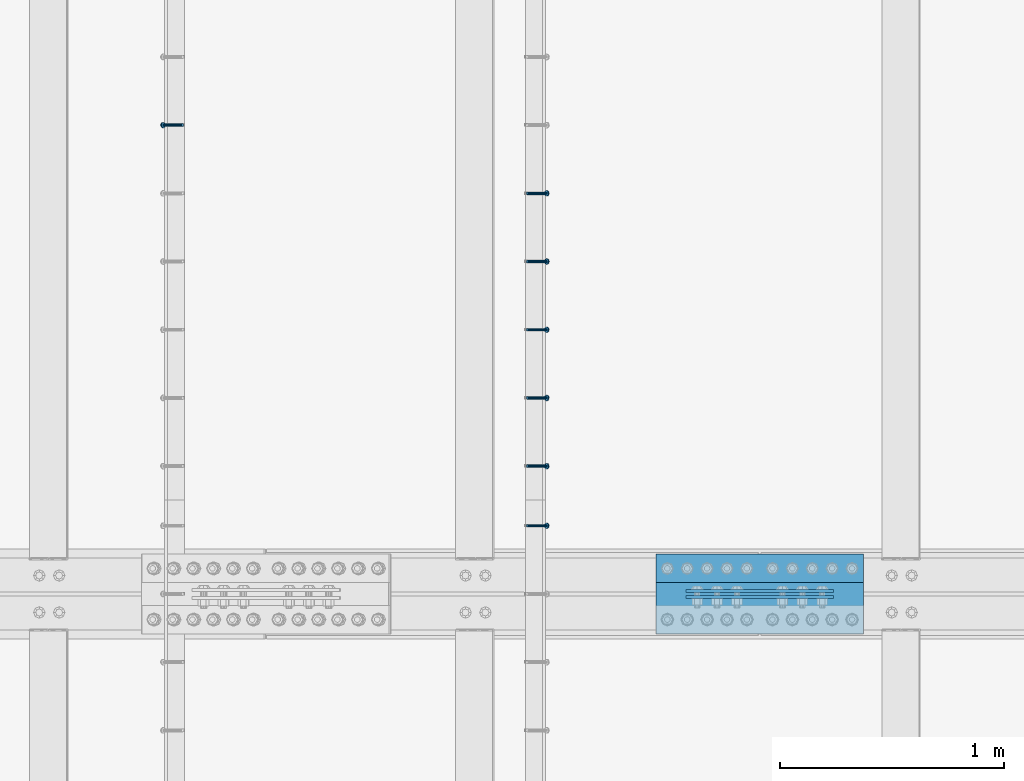
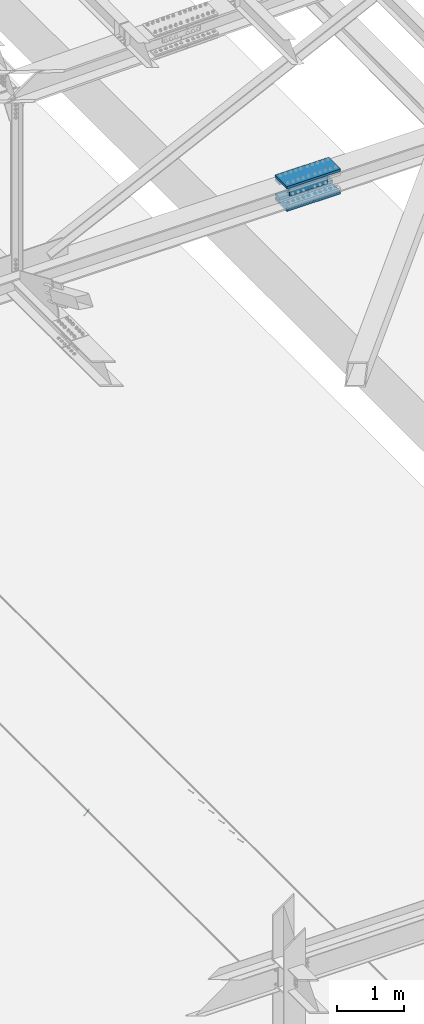
# One storey, part 2273 of 3843: 7 members, 6 beams, 4 elements without a shape of their own.
"""IFC2X3 building model written with IfcOpenShell, lengths in millimetres."""

from ifc_helpers import new_model, si_unit, frame, origin_with_axes, place, context, subcontext, project, spatial, faceted_brep, material, type_object, element, aggregate, save


model = new_model("IFC2X3")

# Units and contexts
model_context = context("Model", 3, precision=1e-05, world=origin_with_axes())
body_context = subcontext(model_context, "Body", "Model", "MODEL_VIEW")
ifc_project = project(units=[si_unit("LENGTHUNIT", "METRE", prefix="MILLI"), si_unit("AREAUNIT", "SQUARE_METRE"), si_unit("VOLUMEUNIT", "CUBIC_METRE"), si_unit("MASSUNIT", "GRAM", prefix="KILO"), si_unit("TIMEUNIT", "SECOND"), si_unit("PLANEANGLEUNIT", "RADIAN"), si_unit("SOLIDANGLEUNIT", "STERADIAN"), si_unit("THERMODYNAMICTEMPERATUREUNIT", "DEGREE_CELSIUS"), si_unit("LUMINOUSINTENSITYUNIT", "LUMEN")], contexts=[model_context])

# Site, building, storey
site_placement = place(None, origin_with_axes())
site = spatial("IfcSite", under=ifc_project, at=site_placement, CompositionType="ELEMENT")
building_placement = place(site_placement, origin_with_axes())
building = spatial("IfcBuilding", under=site, at=building_placement, Name="Undefined", CompositionType="ELEMENT")
storey_placement = place(building_placement, origin_with_axes())
storey = spatial("IfcBuildingStorey", under=building, at=storey_placement, Name="Undefined", CompositionType="ELEMENT", Elevation=0.0)

# Assembly, member
assembly_1_placement = place(storey_placement, origin_with_axes())
assembly_1 = element("IfcElementAssembly", 1, at=assembly_1_placement, inside=storey, Name="EMBED_ANGLE", AssemblyPlace="NOTDEFINED", PredefinedType="RIGID_FRAME")
ifc_material_1 = material(Name="STEEL/A108")
member_type = type_object("IfcMemberType", PredefinedType="NOTDEFINED")
member_1_placement = place(assembly_1_placement, frame((66677.3495, 34150.4271953125, 30446.6625), z_axis=(0.0, 1.0, 0.0), x_axis=(0.707106781186548, 0.0, -0.707106781186548)))
member_1 = element("IfcMember", 2, at=member_1_placement, type_object=member_type, material=ifc_material_1, Name="HEADED STUD ANCHOR", context=body_context, shape_type="Brep", body=[
    faceted_brep([(7.27595761418343e-12, -3.18000006675175, 5.5), (0.0, -5.49999999998363, 3.1800000667572), (118.110000000976, -5.49999999999091, 3.1800000667572), (118.110000000983, -3.18000006675175, 5.5), (0.0, -6.3499999046162, 0.0), (118.110000000968, -6.34999990461256, 0.0), (0.0, -5.49999999998363, -3.1800000667572), (118.110000000976, -5.49999999999091, -3.1800000667572), (7.27595761418343e-12, -3.18000006675175, -5.5), (118.110000000983, -3.18000006675175, -5.5), (7.27595761418343e-12, -1.81898940354586e-12, -6.34999990463257), (118.110000000968, -1.81898940354586e-12, -6.34999990463257), (0.0, 3.18000006675175, -5.5), (118.110000000968, 3.18000006674811, -5.5), (7.27595761418343e-12, 5.49999999998363, -3.1800000667572), (118.110000000983, 5.49999999998363, -3.1800000667572), (7.27595761418343e-12, 6.3499999046162, 0.0), (118.110000000976, 6.34999990461256, 0.0), (7.27595761418343e-12, 5.49999999998363, 3.1800000667572), (118.110000000983, 5.49999999998363, 3.1800000667572), (0.0, 3.18000006675175, 5.5), (118.110000000968, 3.18000006674811, 5.5), (7.27595761418343e-12, -1.81898940354586e-12, 6.34999990463257), (118.110000000968, -1.81898940354586e-12, 6.34999990463257), (120.650000000991, -10.9899997710909, 6.34999990463257), (120.650000000998, -6.34000015257152, 10.9899997711182), (120.650000000991, -12.6999998092379, 0.0), (120.650000000991, -10.9899997710909, -6.34999990463257), (120.650000000998, -6.34000015257152, -10.9899997711182), (120.650000000991, -1.81898940354586e-12, -12.6899995803833), (120.650000000991, 6.34000015257152, -10.9899997711182), (120.650000000998, 10.9899997710909, -6.34999990463257), (120.650000000991, 12.6999998092342, 0.0), (120.650000000998, 10.9899997710909, 6.34999990463257), (120.650000000991, 6.34000015257152, 10.9899997711182), (120.650000000991, -1.81898940354586e-12, 12.6899995803833), (127.000000001048, -10.9899997710945, 6.34999990463257), (127.000000001048, -6.34000015257152, 10.9899997711182), (127.000000001048, -12.6999998092342, 0.0), (127.000000001048, -10.9899997710945, -6.34999990463257), (127.000000001048, -6.34000015257152, -10.9899997711182), (127.000000001048, 1.81898940354586e-12, -12.6899995803833), (127.000000001048, 6.34000015256788, -10.9899997711182), (127.000000001048, 10.9899997710909, -6.34999990463257), (127.000000001048, 12.6999998092379, 0.0), (127.000000001048, 10.9899997710909, 6.34999990463257), (127.000000001048, 6.34000015256788, 10.9899997711182), (127.000000001048, 1.81898940354586e-12, 12.6899995803833)], [[[0, 1, 2, 3]], [[1, 4, 5, 2]], [[4, 6, 7, 5]], [[6, 8, 9, 7]], [[8, 10, 11, 9]], [[10, 12, 13, 11]], [[12, 14, 15, 13]], [[14, 16, 17, 15]], [[16, 18, 19, 17]], [[18, 20, 21, 19]], [[20, 22, 23, 21]], [[22, 0, 3, 23]], [[22, 20, 18, 16, 14, 12, 10, 8, 6, 4, 1, 0]], [[3, 2, 24, 25]], [[2, 5, 26, 24]], [[5, 7, 27, 26]], [[7, 9, 28, 27]], [[9, 11, 29, 28]], [[11, 13, 30, 29]], [[13, 15, 31, 30]], [[15, 17, 32, 31]], [[17, 19, 33, 32]], [[19, 21, 34, 33]], [[21, 23, 35, 34]], [[23, 3, 25, 35]], [[25, 24, 36, 37]], [[24, 26, 38, 36]], [[26, 27, 39, 38]], [[27, 28, 40, 39]], [[28, 29, 41, 40]], [[29, 30, 42, 41]], [[30, 31, 43, 42]], [[31, 32, 44, 43]], [[32, 33, 45, 44]], [[33, 34, 46, 45]], [[34, 35, 47, 46]], [[35, 25, 37, 47]], [[38, 39, 40, 41, 42, 43, 44, 45, 46, 47, 37, 36]]]),
])
aggregate(assembly_1, [member_1])

# Assembly, members
assembly_2_placement = place(storey_placement, origin_with_axes())
assembly_2 = element("IfcElementAssembly", 3, at=assembly_2_placement, inside=storey, Name="EMBED_ANGLE", AssemblyPlace="NOTDEFINED", PredefinedType="RIGID_FRAME")
member_2_placement = place(assembly_2_placement, frame((66677.3495, 34417.000201416, 30446.6625), z_axis=(0.0, 1.0, 0.0), x_axis=(0.707106781186548, 0.0, -0.707106781186548)))
member_2 = element("IfcMember", 4, at=member_2_placement, type_object=member_type, material=ifc_material_1, Name="HEADED STUD ANCHOR", context=body_context, shape_type="Brep", body=[
    faceted_brep([(7.27595761418343e-12, -3.18000006675175, 5.5), (0.0, -5.49999999998363, 3.1800000667572), (118.110000000976, -5.49999999999091, 3.1800000667572), (118.110000000983, -3.18000006675175, 5.5), (0.0, -6.3499999046162, 0.0), (118.110000000968, -6.34999990461256, 0.0), (0.0, -5.49999999998363, -3.1800000667572), (118.110000000976, -5.49999999999091, -3.1800000667572), (7.27595761418343e-12, -3.18000006675175, -5.5), (118.110000000983, -3.18000006675175, -5.5), (7.27595761418343e-12, -1.81898940354586e-12, -6.34999990463257), (118.110000000968, -1.81898940354586e-12, -6.34999990463257), (0.0, 3.18000006675175, -5.5), (118.110000000968, 3.18000006674811, -5.5), (7.27595761418343e-12, 5.49999999998363, -3.1800000667572), (118.110000000983, 5.49999999998363, -3.1800000667572), (7.27595761418343e-12, 6.3499999046162, 0.0), (118.110000000976, 6.34999990461256, 0.0), (7.27595761418343e-12, 5.49999999998363, 3.1800000667572), (118.110000000983, 5.49999999998363, 3.1800000667572), (0.0, 3.18000006675175, 5.5), (118.110000000968, 3.18000006674811, 5.5), (7.27595761418343e-12, -1.81898940354586e-12, 6.34999990463257), (118.110000000968, -1.81898940354586e-12, 6.34999990463257), (120.650000000991, -10.9899997710909, 6.34999990463257), (120.650000000998, -6.34000015257152, 10.9899997711182), (120.650000000991, -12.6999998092379, 0.0), (120.650000000991, -10.9899997710909, -6.34999990463257), (120.650000000998, -6.34000015257152, -10.9899997711182), (120.650000000991, -1.81898940354586e-12, -12.6899995803833), (120.650000000991, 6.34000015257152, -10.9899997711182), (120.650000000998, 10.9899997710909, -6.34999990463257), (120.650000000991, 12.6999998092342, 0.0), (120.650000000998, 10.9899997710909, 6.34999990463257), (120.650000000991, 6.34000015257152, 10.9899997711182), (120.650000000991, -1.81898940354586e-12, 12.6899995803833), (127.000000001048, -10.9899997710945, 6.34999990463257), (127.000000001048, -6.34000015257152, 10.9899997711182), (127.000000001048, -12.6999998092342, 0.0), (127.000000001048, -10.9899997710945, -6.34999990463257), (127.000000001048, -6.34000015257152, -10.9899997711182), (127.000000001048, 1.81898940354586e-12, -12.6899995803833), (127.000000001048, 6.34000015256788, -10.9899997711182), (127.000000001048, 10.9899997710909, -6.34999990463257), (127.000000001048, 12.6999998092379, 0.0), (127.000000001048, 10.9899997710909, 6.34999990463257), (127.000000001048, 6.34000015256788, 10.9899997711182), (127.000000001048, 1.81898940354586e-12, 12.6899995803833)], [[[0, 1, 2, 3]], [[1, 4, 5, 2]], [[4, 6, 7, 5]], [[6, 8, 9, 7]], [[8, 10, 11, 9]], [[10, 12, 13, 11]], [[12, 14, 15, 13]], [[14, 16, 17, 15]], [[16, 18, 19, 17]], [[18, 20, 21, 19]], [[20, 22, 23, 21]], [[22, 0, 3, 23]], [[22, 20, 18, 16, 14, 12, 10, 8, 6, 4, 1, 0]], [[3, 2, 24, 25]], [[2, 5, 26, 24]], [[5, 7, 27, 26]], [[7, 9, 28, 27]], [[9, 11, 29, 28]], [[11, 13, 30, 29]], [[13, 15, 31, 30]], [[15, 17, 32, 31]], [[17, 19, 33, 32]], [[19, 21, 34, 33]], [[21, 23, 35, 34]], [[23, 3, 25, 35]], [[25, 24, 36, 37]], [[24, 26, 38, 36]], [[26, 27, 39, 38]], [[27, 28, 40, 39]], [[28, 29, 41, 40]], [[29, 30, 42, 41]], [[30, 31, 43, 42]], [[31, 32, 44, 43]], [[32, 33, 45, 44]], [[33, 34, 46, 45]], [[34, 35, 47, 46]], [[35, 25, 37, 47]], [[38, 39, 40, 41, 42, 43, 44, 45, 46, 47, 37, 36]]]),
])
member_3_placement = place(assembly_2_placement, frame((66677.3495, 34721.800201416, 30446.6625), z_axis=(0.0, 1.0, 0.0), x_axis=(0.707106781186548, 0.0, -0.707106781186548)))
member_3 = element("IfcMember", 5, at=member_3_placement, type_object=member_type, material=ifc_material_1, Name="HEADED STUD ANCHOR", context=body_context, shape_type="Brep", body=[
    faceted_brep([(7.27595761418343e-12, -3.18000006675175, 5.5), (0.0, -5.49999999998363, 3.1800000667572), (118.110000000976, -5.49999999999091, 3.1800000667572), (118.110000000983, -3.18000006675175, 5.5), (0.0, -6.3499999046162, 0.0), (118.110000000968, -6.34999990461256, 0.0), (0.0, -5.49999999998363, -3.1800000667572), (118.110000000976, -5.49999999999091, -3.1800000667572), (7.27595761418343e-12, -3.18000006675175, -5.5), (118.110000000983, -3.18000006675175, -5.5), (7.27595761418343e-12, -1.81898940354586e-12, -6.34999990463257), (118.110000000968, -1.81898940354586e-12, -6.34999990463257), (0.0, 3.18000006675175, -5.5), (118.110000000968, 3.18000006674811, -5.5), (7.27595761418343e-12, 5.49999999998363, -3.1800000667572), (118.110000000983, 5.49999999998363, -3.1800000667572), (7.27595761418343e-12, 6.3499999046162, 0.0), (118.110000000976, 6.34999990461256, 0.0), (7.27595761418343e-12, 5.49999999998363, 3.1800000667572), (118.110000000983, 5.49999999998363, 3.1800000667572), (0.0, 3.18000006675175, 5.5), (118.110000000968, 3.18000006674811, 5.5), (7.27595761418343e-12, -1.81898940354586e-12, 6.34999990463257), (118.110000000968, -1.81898940354586e-12, 6.34999990463257), (120.650000000991, -10.9899997710909, 6.34999990463257), (120.650000000998, -6.34000015257152, 10.9899997711182), (120.650000000991, -12.6999998092379, 0.0), (120.650000000991, -10.9899997710909, -6.34999990463257), (120.650000000998, -6.34000015257152, -10.9899997711182), (120.650000000991, -1.81898940354586e-12, -12.6899995803833), (120.650000000991, 6.34000015257152, -10.9899997711182), (120.650000000998, 10.9899997710909, -6.34999990463257), (120.650000000991, 12.6999998092342, 0.0), (120.650000000998, 10.9899997710909, 6.34999990463257), (120.650000000991, 6.34000015257152, 10.9899997711182), (120.650000000991, -1.81898940354586e-12, 12.6899995803833), (127.000000001048, -10.9899997710945, 6.34999990463257), (127.000000001048, -6.34000015257152, 10.9899997711182), (127.000000001048, -12.6999998092342, 0.0), (127.000000001048, -10.9899997710945, -6.34999990463257), (127.000000001048, -6.34000015257152, -10.9899997711182), (127.000000001048, 1.81898940354586e-12, -12.6899995803833), (127.000000001048, 6.34000015256788, -10.9899997711182), (127.000000001048, 10.9899997710909, -6.34999990463257), (127.000000001048, 12.6999998092379, 0.0), (127.000000001048, 10.9899997710909, 6.34999990463257), (127.000000001048, 6.34000015256788, 10.9899997711182), (127.000000001048, 1.81898940354586e-12, 12.6899995803833)], [[[0, 1, 2, 3]], [[1, 4, 5, 2]], [[4, 6, 7, 5]], [[6, 8, 9, 7]], [[8, 10, 11, 9]], [[10, 12, 13, 11]], [[12, 14, 15, 13]], [[14, 16, 17, 15]], [[16, 18, 19, 17]], [[18, 20, 21, 19]], [[20, 22, 23, 21]], [[22, 0, 3, 23]], [[22, 20, 18, 16, 14, 12, 10, 8, 6, 4, 1, 0]], [[3, 2, 24, 25]], [[2, 5, 26, 24]], [[5, 7, 27, 26]], [[7, 9, 28, 27]], [[9, 11, 29, 28]], [[11, 13, 30, 29]], [[13, 15, 31, 30]], [[15, 17, 32, 31]], [[17, 19, 33, 32]], [[19, 21, 34, 33]], [[21, 23, 35, 34]], [[23, 3, 25, 35]], [[25, 24, 36, 37]], [[24, 26, 38, 36]], [[26, 27, 39, 38]], [[27, 28, 40, 39]], [[28, 29, 41, 40]], [[29, 30, 42, 41]], [[30, 31, 43, 42]], [[31, 32, 44, 43]], [[32, 33, 45, 44]], [[33, 34, 46, 45]], [[34, 35, 47, 46]], [[35, 25, 37, 47]], [[38, 39, 40, 41, 42, 43, 44, 45, 46, 47, 37, 36]]]),
])
member_4_placement = place(assembly_2_placement, frame((66677.3495, 35026.600201416, 30446.6625), z_axis=(0.0, 1.0, 0.0), x_axis=(0.707106781186548, 0.0, -0.707106781186548)))
member_4 = element("IfcMember", 6, at=member_4_placement, type_object=member_type, material=ifc_material_1, Name="HEADED STUD ANCHOR", context=body_context, shape_type="Brep", body=[
    faceted_brep([(7.27595761418343e-12, -3.18000006675175, 5.5), (0.0, -5.49999999998363, 3.1800000667572), (118.110000000976, -5.49999999999091, 3.1800000667572), (118.110000000983, -3.18000006675175, 5.5), (0.0, -6.3499999046162, 0.0), (118.110000000968, -6.34999990461256, 0.0), (0.0, -5.49999999998363, -3.1800000667572), (118.110000000976, -5.49999999999091, -3.1800000667572), (7.27595761418343e-12, -3.18000006675175, -5.5), (118.110000000983, -3.18000006675175, -5.5), (7.27595761418343e-12, -1.81898940354586e-12, -6.34999990463257), (118.110000000968, -1.81898940354586e-12, -6.34999990463257), (0.0, 3.18000006675175, -5.5), (118.110000000968, 3.18000006674811, -5.5), (7.27595761418343e-12, 5.49999999998363, -3.1800000667572), (118.110000000983, 5.49999999998363, -3.1800000667572), (7.27595761418343e-12, 6.3499999046162, 0.0), (118.110000000976, 6.34999990461256, 0.0), (7.27595761418343e-12, 5.49999999998363, 3.1800000667572), (118.110000000983, 5.49999999998363, 3.1800000667572), (0.0, 3.18000006675175, 5.5), (118.110000000968, 3.18000006674811, 5.5), (7.27595761418343e-12, -1.81898940354586e-12, 6.34999990463257), (118.110000000968, -1.81898940354586e-12, 6.34999990463257), (120.650000000991, -10.9899997710909, 6.34999990463257), (120.650000000998, -6.34000015257152, 10.9899997711182), (120.650000000991, -12.6999998092379, 0.0), (120.650000000991, -10.9899997710909, -6.34999990463257), (120.650000000998, -6.34000015257152, -10.9899997711182), (120.650000000991, -1.81898940354586e-12, -12.6899995803833), (120.650000000991, 6.34000015257152, -10.9899997711182), (120.650000000998, 10.9899997710909, -6.34999990463257), (120.650000000991, 12.6999998092342, 0.0), (120.650000000998, 10.9899997710909, 6.34999990463257), (120.650000000991, 6.34000015257152, 10.9899997711182), (120.650000000991, -1.81898940354586e-12, 12.6899995803833), (127.000000001048, -10.9899997710945, 6.34999990463257), (127.000000001048, -6.34000015257152, 10.9899997711182), (127.000000001048, -12.6999998092342, 0.0), (127.000000001048, -10.9899997710945, -6.34999990463257), (127.000000001048, -6.34000015257152, -10.9899997711182), (127.000000001048, 1.81898940354586e-12, -12.6899995803833), (127.000000001048, 6.34000015256788, -10.9899997711182), (127.000000001048, 10.9899997710909, -6.34999990463257), (127.000000001048, 12.6999998092379, 0.0), (127.000000001048, 10.9899997710909, 6.34999990463257), (127.000000001048, 6.34000015256788, 10.9899997711182), (127.000000001048, 1.81898940354586e-12, 12.6899995803833)], [[[0, 1, 2, 3]], [[1, 4, 5, 2]], [[4, 6, 7, 5]], [[6, 8, 9, 7]], [[8, 10, 11, 9]], [[10, 12, 13, 11]], [[12, 14, 15, 13]], [[14, 16, 17, 15]], [[16, 18, 19, 17]], [[18, 20, 21, 19]], [[20, 22, 23, 21]], [[22, 0, 3, 23]], [[22, 20, 18, 16, 14, 12, 10, 8, 6, 4, 1, 0]], [[3, 2, 24, 25]], [[2, 5, 26, 24]], [[5, 7, 27, 26]], [[7, 9, 28, 27]], [[9, 11, 29, 28]], [[11, 13, 30, 29]], [[13, 15, 31, 30]], [[15, 17, 32, 31]], [[17, 19, 33, 32]], [[19, 21, 34, 33]], [[21, 23, 35, 34]], [[23, 3, 25, 35]], [[25, 24, 36, 37]], [[24, 26, 38, 36]], [[26, 27, 39, 38]], [[27, 28, 40, 39]], [[28, 29, 41, 40]], [[29, 30, 42, 41]], [[30, 31, 43, 42]], [[31, 32, 44, 43]], [[32, 33, 45, 44]], [[33, 34, 46, 45]], [[34, 35, 47, 46]], [[35, 25, 37, 47]], [[38, 39, 40, 41, 42, 43, 44, 45, 46, 47, 37, 36]]]),
])
member_5_placement = place(assembly_2_placement, frame((66677.3495, 35331.400201416, 30446.6625), z_axis=(0.0, 1.0, 0.0), x_axis=(0.707106781186548, 0.0, -0.707106781186548)))
member_5 = element("IfcMember", 7, at=member_5_placement, type_object=member_type, material=ifc_material_1, Name="HEADED STUD ANCHOR", context=body_context, shape_type="Brep", body=[
    faceted_brep([(7.27595761418343e-12, -3.18000006675175, 5.5), (0.0, -5.49999999998363, 3.1800000667572), (118.110000000976, -5.49999999999091, 3.1800000667572), (118.110000000983, -3.18000006675175, 5.5), (0.0, -6.3499999046162, 0.0), (118.110000000968, -6.34999990461256, 0.0), (0.0, -5.49999999998363, -3.1800000667572), (118.110000000976, -5.49999999999091, -3.1800000667572), (7.27595761418343e-12, -3.18000006675175, -5.5), (118.110000000983, -3.18000006675175, -5.5), (7.27595761418343e-12, -1.81898940354586e-12, -6.34999990463257), (118.110000000968, -1.81898940354586e-12, -6.34999990463257), (0.0, 3.18000006675175, -5.5), (118.110000000968, 3.18000006674811, -5.5), (7.27595761418343e-12, 5.49999999998363, -3.1800000667572), (118.110000000983, 5.49999999998363, -3.1800000667572), (7.27595761418343e-12, 6.3499999046162, 0.0), (118.110000000976, 6.34999990461256, 0.0), (7.27595761418343e-12, 5.49999999998363, 3.1800000667572), (118.110000000983, 5.49999999998363, 3.1800000667572), (0.0, 3.18000006675175, 5.5), (118.110000000968, 3.18000006674811, 5.5), (7.27595761418343e-12, -1.81898940354586e-12, 6.34999990463257), (118.110000000968, -1.81898940354586e-12, 6.34999990463257), (120.650000000991, -10.9899997710909, 6.34999990463257), (120.650000000998, -6.34000015257152, 10.9899997711182), (120.650000000991, -12.6999998092379, 0.0), (120.650000000991, -10.9899997710909, -6.34999990463257), (120.650000000998, -6.34000015257152, -10.9899997711182), (120.650000000991, -1.81898940354586e-12, -12.6899995803833), (120.650000000991, 6.34000015257152, -10.9899997711182), (120.650000000998, 10.9899997710909, -6.34999990463257), (120.650000000991, 12.6999998092342, 0.0), (120.650000000998, 10.9899997710909, 6.34999990463257), (120.650000000991, 6.34000015257152, 10.9899997711182), (120.650000000991, -1.81898940354586e-12, 12.6899995803833), (127.000000001048, -10.9899997710945, 6.34999990463257), (127.000000001048, -6.34000015257152, 10.9899997711182), (127.000000001048, -12.6999998092342, 0.0), (127.000000001048, -10.9899997710945, -6.34999990463257), (127.000000001048, -6.34000015257152, -10.9899997711182), (127.000000001048, 1.81898940354586e-12, -12.6899995803833), (127.000000001048, 6.34000015256788, -10.9899997711182), (127.000000001048, 10.9899997710909, -6.34999990463257), (127.000000001048, 12.6999998092379, 0.0), (127.000000001048, 10.9899997710909, 6.34999990463257), (127.000000001048, 6.34000015256788, 10.9899997711182), (127.000000001048, 1.81898940354586e-12, 12.6899995803833)], [[[0, 1, 2, 3]], [[1, 4, 5, 2]], [[4, 6, 7, 5]], [[6, 8, 9, 7]], [[8, 10, 11, 9]], [[10, 12, 13, 11]], [[12, 14, 15, 13]], [[14, 16, 17, 15]], [[16, 18, 19, 17]], [[18, 20, 21, 19]], [[20, 22, 23, 21]], [[22, 0, 3, 23]], [[22, 20, 18, 16, 14, 12, 10, 8, 6, 4, 1, 0]], [[3, 2, 24, 25]], [[2, 5, 26, 24]], [[5, 7, 27, 26]], [[7, 9, 28, 27]], [[9, 11, 29, 28]], [[11, 13, 30, 29]], [[13, 15, 31, 30]], [[15, 17, 32, 31]], [[17, 19, 33, 32]], [[19, 21, 34, 33]], [[21, 23, 35, 34]], [[23, 3, 25, 35]], [[25, 24, 36, 37]], [[24, 26, 38, 36]], [[26, 27, 39, 38]], [[27, 28, 40, 39]], [[28, 29, 41, 40]], [[29, 30, 42, 41]], [[30, 31, 43, 42]], [[31, 32, 44, 43]], [[32, 33, 45, 44]], [[33, 34, 46, 45]], [[34, 35, 47, 46]], [[35, 25, 37, 47]], [[38, 39, 40, 41, 42, 43, 44, 45, 46, 47, 37, 36]]]),
])
member_6_placement = place(assembly_2_placement, frame((66677.3495, 35636.200201416, 30446.6625), z_axis=(0.0, 1.0, 0.0), x_axis=(0.707106781186548, 0.0, -0.707106781186548)))
member_6 = element("IfcMember", 8, at=member_6_placement, type_object=member_type, material=ifc_material_1, Name="HEADED STUD ANCHOR", context=body_context, shape_type="Brep", body=[
    faceted_brep([(7.27595761418343e-12, -3.18000006675175, 5.5), (0.0, -5.49999999998363, 3.1800000667572), (118.110000000976, -5.49999999999091, 3.1800000667572), (118.110000000983, -3.18000006675175, 5.5), (0.0, -6.3499999046162, 0.0), (118.110000000968, -6.34999990461256, 0.0), (0.0, -5.49999999998363, -3.1800000667572), (118.110000000976, -5.49999999999091, -3.1800000667572), (7.27595761418343e-12, -3.18000006675175, -5.5), (118.110000000983, -3.18000006675175, -5.5), (7.27595761418343e-12, -1.81898940354586e-12, -6.34999990463257), (118.110000000968, -1.81898940354586e-12, -6.34999990463257), (0.0, 3.18000006675175, -5.5), (118.110000000968, 3.18000006674811, -5.5), (7.27595761418343e-12, 5.49999999998363, -3.1800000667572), (118.110000000983, 5.49999999998363, -3.1800000667572), (7.27595761418343e-12, 6.3499999046162, 0.0), (118.110000000976, 6.34999990461256, 0.0), (7.27595761418343e-12, 5.49999999998363, 3.1800000667572), (118.110000000983, 5.49999999998363, 3.1800000667572), (0.0, 3.18000006675175, 5.5), (118.110000000968, 3.18000006674811, 5.5), (7.27595761418343e-12, -1.81898940354586e-12, 6.34999990463257), (118.110000000968, -1.81898940354586e-12, 6.34999990463257), (120.650000000991, -10.9899997710909, 6.34999990463257), (120.650000000998, -6.34000015257152, 10.9899997711182), (120.650000000991, -12.6999998092379, 0.0), (120.650000000991, -10.9899997710909, -6.34999990463257), (120.650000000998, -6.34000015257152, -10.9899997711182), (120.650000000991, -1.81898940354586e-12, -12.6899995803833), (120.650000000991, 6.34000015257152, -10.9899997711182), (120.650000000998, 10.9899997710909, -6.34999990463257), (120.650000000991, 12.6999998092342, 0.0), (120.650000000998, 10.9899997710909, 6.34999990463257), (120.650000000991, 6.34000015257152, 10.9899997711182), (120.650000000991, -1.81898940354586e-12, 12.6899995803833), (127.000000001048, -10.9899997710945, 6.34999990463257), (127.000000001048, -6.34000015257152, 10.9899997711182), (127.000000001048, -12.6999998092342, 0.0), (127.000000001048, -10.9899997710945, -6.34999990463257), (127.000000001048, -6.34000015257152, -10.9899997711182), (127.000000001048, 1.81898940354586e-12, -12.6899995803833), (127.000000001048, 6.34000015256788, -10.9899997711182), (127.000000001048, 10.9899997710909, -6.34999990463257), (127.000000001048, 12.6999998092379, 0.0), (127.000000001048, 10.9899997710909, 6.34999990463257), (127.000000001048, 6.34000015256788, 10.9899997711182), (127.000000001048, 1.81898940354586e-12, 12.6899995803833)], [[[0, 1, 2, 3]], [[1, 4, 5, 2]], [[4, 6, 7, 5]], [[6, 8, 9, 7]], [[8, 10, 11, 9]], [[10, 12, 13, 11]], [[12, 14, 15, 13]], [[14, 16, 17, 15]], [[16, 18, 19, 17]], [[18, 20, 21, 19]], [[20, 22, 23, 21]], [[22, 0, 3, 23]], [[22, 20, 18, 16, 14, 12, 10, 8, 6, 4, 1, 0]], [[3, 2, 24, 25]], [[2, 5, 26, 24]], [[5, 7, 27, 26]], [[7, 9, 28, 27]], [[9, 11, 29, 28]], [[11, 13, 30, 29]], [[13, 15, 31, 30]], [[15, 17, 32, 31]], [[17, 19, 33, 32]], [[19, 21, 34, 33]], [[21, 23, 35, 34]], [[23, 3, 25, 35]], [[25, 24, 36, 37]], [[24, 26, 38, 36]], [[26, 27, 39, 38]], [[27, 28, 40, 39]], [[28, 29, 41, 40]], [[29, 30, 42, 41]], [[30, 31, 43, 42]], [[31, 32, 44, 43]], [[32, 33, 45, 44]], [[33, 34, 46, 45]], [[34, 35, 47, 46]], [[35, 25, 37, 47]], [[38, 39, 40, 41, 42, 43, 44, 45, 46, 47, 37, 36]]]),
])
aggregate(assembly_2, [member_2, member_3, member_4, member_5, member_6])

# Assembly, member
assembly_3_placement = place(storey_placement, origin_with_axes())
assembly_3 = element("IfcElementAssembly", 9, at=assembly_3_placement, inside=storey, Name="EMBED_ANGLE", AssemblyPlace="NOTDEFINED", PredefinedType="RIGID_FRAME")
member_7_placement = place(assembly_3_placement, frame((65137.5380556641, 35941.000201416, 30446.6625), z_axis=(0.0, 1.0, 0.0), x_axis=(-0.707106781186548, 0.0, -0.707106781186548)))
member_7 = element("IfcMember", 10, at=member_7_placement, type_object=member_type, material=ifc_material_1, Name="HEADED STUD ANCHOR", context=body_context, shape_type="Brep", body=[
    faceted_brep([(7.27595761418343e-12, -3.18000006675175, 5.5), (0.0, -5.49999999998363, 3.1800000667572), (118.110000000976, -5.49999999999091, 3.1800000667572), (118.110000000983, -3.18000006675175, 5.5), (0.0, -6.3499999046162, 0.0), (118.110000000968, -6.34999990461256, 0.0), (0.0, -5.49999999998363, -3.1800000667572), (118.110000000976, -5.49999999999091, -3.1800000667572), (7.27595761418343e-12, -3.18000006675175, -5.5), (118.110000000983, -3.18000006675175, -5.5), (7.27595761418343e-12, -1.81898940354586e-12, -6.34999990463257), (118.110000000968, -1.81898940354586e-12, -6.34999990463257), (0.0, 3.18000006675175, -5.5), (118.110000000968, 3.18000006674811, -5.5), (7.27595761418343e-12, 5.49999999998363, -3.1800000667572), (118.110000000983, 5.49999999998363, -3.1800000667572), (7.27595761418343e-12, 6.3499999046162, 0.0), (118.110000000976, 6.34999990461256, 0.0), (7.27595761418343e-12, 5.49999999998363, 3.1800000667572), (118.110000000983, 5.49999999998363, 3.1800000667572), (0.0, 3.18000006675175, 5.5), (118.110000000968, 3.18000006674811, 5.5), (7.27595761418343e-12, -1.81898940354586e-12, 6.34999990463257), (118.110000000968, -1.81898940354586e-12, 6.34999990463257), (120.650000000991, -10.9899997710909, 6.34999990463257), (120.650000000998, -6.34000015257152, 10.9899997711182), (120.650000000991, -12.6999998092379, 0.0), (120.650000000991, -10.9899997710909, -6.34999990463257), (120.650000000998, -6.34000015257152, -10.9899997711182), (120.650000000991, -1.81898940354586e-12, -12.6899995803833), (120.650000000991, 6.34000015257152, -10.9899997711182), (120.650000000998, 10.9899997710909, -6.34999990463257), (120.650000000991, 12.6999998092342, 0.0), (120.650000000998, 10.9899997710909, 6.34999990463257), (120.650000000991, 6.34000015257152, 10.9899997711182), (120.650000000991, -1.81898940354586e-12, 12.6899995803833), (127.000000001048, -10.9899997710945, 6.34999990463257), (127.000000001048, -6.34000015257152, 10.9899997711182), (127.000000001048, -12.6999998092342, 0.0), (127.000000001048, -10.9899997710945, -6.34999990463257), (127.000000001048, -6.34000015257152, -10.9899997711182), (127.000000001048, 1.81898940354586e-12, -12.6899995803833), (127.000000001048, 6.34000015256788, -10.9899997711182), (127.000000001048, 10.9899997710909, -6.34999990463257), (127.000000001048, 12.6999998092379, 0.0), (127.000000001048, 10.9899997710909, 6.34999990463257), (127.000000001048, 6.34000015256788, 10.9899997711182), (127.000000001048, 1.81898940354586e-12, 12.6899995803833)], [[[0, 1, 2, 3]], [[1, 4, 5, 2]], [[4, 6, 7, 5]], [[6, 8, 9, 7]], [[8, 10, 11, 9]], [[10, 12, 13, 11]], [[12, 14, 15, 13]], [[14, 16, 17, 15]], [[16, 18, 19, 17]], [[18, 20, 21, 19]], [[20, 22, 23, 21]], [[22, 0, 3, 23]], [[22, 20, 18, 16, 14, 12, 10, 8, 6, 4, 1, 0]], [[3, 2, 24, 25]], [[2, 5, 26, 24]], [[5, 7, 27, 26]], [[7, 9, 28, 27]], [[9, 11, 29, 28]], [[11, 13, 30, 29]], [[13, 15, 31, 30]], [[15, 17, 32, 31]], [[17, 19, 33, 32]], [[19, 21, 34, 33]], [[21, 23, 35, 34]], [[23, 3, 25, 35]], [[25, 24, 36, 37]], [[24, 26, 38, 36]], [[26, 27, 39, 38]], [[27, 28, 40, 39]], [[28, 29, 41, 40]], [[29, 30, 42, 41]], [[30, 31, 43, 42]], [[31, 32, 44, 43]], [[32, 33, 45, 44]], [[33, 34, 46, 45]], [[34, 35, 47, 46]], [[35, 25, 37, 47]], [[38, 39, 40, 41, 42, 43, 44, 45, 46, 47, 37, 36]]]),
])
aggregate(assembly_3, [member_7])

# Assembly, beams
assembly_4_placement = place(storey_placement, origin_with_axes())
assembly_4 = element("IfcElementAssembly", 11, at=assembly_4_placement, inside=storey, Name="BEAM", AssemblyPlace="NOTDEFINED", PredefinedType="RIGID_FRAME")
ifc_material_2 = material(Name="STEEL/A572-50")
beam_type_1 = type_object("IfcBeamType", PredefinedType="NOTDEFINED")
beam_1_placement = place(assembly_4_placement, frame((68046.5999614081, 33832.00625, 42261.7444794972), z_axis=(-0.00048281500021403, 0.0, 0.999999883444831), x_axis=(-0.999999883445314, 0.0, -0.000482814000210543)))
beam_1 = element("IfcBeam", 12, at=beam_1_placement, type_object=beam_type_1, material=ifc_material_2, Name="PLATE", context=body_context, shape_type="Brep", body=[
    faceted_brep([(1.45519152283669e-11, 6.35000000000582, -88.8999999998996), (0.0, 6.34999999999854, 88.9000015258789), (660.399999982677, 6.35000000000582, 88.8999999999651), (660.399999982707, 6.35000000000582, -88.8999999998268), (0.0, -6.34999999999854, 88.9000015258789), (660.399999982677, -6.35000000000582, 88.8999999999651), (1.45519152283669e-11, -6.35000000000582, -88.8999999998996), (660.399999982707, -6.35000000000582, -88.8999999998268)], [[[0, 1, 2, 3]], [[1, 4, 5, 2]], [[4, 6, 7, 5]], [[6, 0, 3, 7]], [[5, 7, 3, 2]], [[6, 4, 1, 0]]]),
])
beam_2_placement = place(assembly_4_placement, frame((68046.5999614081, 33858.99375, 42261.7444794972), z_axis=(-0.00048281500021403, 0.0, 0.999999883444831), x_axis=(-0.999999883445314, 0.0, -0.000482814000210543)))
beam_2 = element("IfcBeam", 13, at=beam_2_placement, type_object=beam_type_1, material=ifc_material_2, Name="PLATE", context=body_context, shape_type="Brep", body=[
    faceted_brep([(1.45519152283669e-11, 6.35000000000582, -88.8999999998996), (0.0, 6.34999999999854, 88.9000015258789), (660.399999982677, 6.35000000000582, 88.8999999999651), (660.399999982707, 6.35000000000582, -88.8999999998268), (0.0, -6.34999999999854, 88.9000015258789), (660.399999982677, -6.35000000000582, 88.8999999999651), (1.45519152283669e-11, -6.35000000000582, -88.8999999998996), (660.399999982707, -6.35000000000582, -88.8999999998268)], [[[0, 1, 2, 3]], [[1, 4, 5, 2]], [[4, 6, 7, 5]], [[6, 0, 3, 7]], [[5, 7, 3, 2]], [[6, 4, 1, 0]]]),
])
beam_type_2 = type_object("IfcBeamType", PredefinedType="NOTDEFINED")
beam_3_placement = place(assembly_4_placement, frame((68179.8503049151, 33845.5, 42468.1838388258), z_axis=(0.0, 1.0, 0.0), x_axis=(-0.999999883445314, 0.0, -0.000482814000210543)))
beam_3 = element("IfcBeam", 14, at=beam_3_placement, type_object=beam_type_2, material=ifc_material_2, Name="PLATE", context=body_context, shape_type="Brep", body=[
    faceted_brep([(0.0, 22.2249999999767, -177.800000000003), (0.0, 22.2249999999767, 177.800000000003), (927.099999958984, 22.2250000000859, 177.800000000003), (927.099999958984, 22.2250000000859, -177.800000000003), (0.0, -22.2249999999694, 177.800000000003), (927.099999958984, -22.2249999998749, 177.800000000003), (0.0, -22.2249999999694, -177.800000000003), (927.099999958984, -22.2249999998749, -177.800000000003)], [[[0, 1, 2, 3]], [[1, 4, 5, 2]], [[4, 6, 7, 5]], [[6, 0, 3, 7]], [[5, 7, 3, 2]], [[6, 4, 1, 0]]]),
])
beam_4_placement = place(assembly_4_placement, frame((68180.0495868054, 33845.5, 42055.4338868897), z_axis=(0.0, 1.0, 0.0), x_axis=(-0.999999883445314, 0.0, -0.000482814000210543)))
beam_4 = element("IfcBeam", 15, at=beam_4_placement, type_object=beam_type_2, material=ifc_material_2, Name="PLATE", context=body_context, shape_type="Brep", body=[
    faceted_brep([(0.0, 22.2249999999767, -177.800000000003), (0.0, 22.2249999999767, 177.800000000003), (927.099999958984, 22.2250000000859, 177.800000000003), (927.099999958984, 22.2250000000859, -177.800000000003), (0.0, -22.2249999999694, 177.800000000003), (927.099999958984, -22.2249999998749, 177.800000000003), (0.0, -22.2249999999694, -177.800000000003), (927.099999958984, -22.2249999998749, -177.800000000003)], [[[0, 1, 2, 3]], [[1, 4, 5, 2]], [[4, 6, 7, 5]], [[6, 0, 3, 7]], [[5, 7, 3, 2]], [[6, 4, 1, 0]]]),
])
beam_type_3 = type_object("IfcBeamType", PredefinedType="NOTDEFINED")
beam_5_placement = place(assembly_4_placement, frame((67252.9167367417, 33959.8, 42123.2487611883), z_axis=(0.0, 1.0, 0.0), x_axis=(0.999999883444831, 0.0, 0.000482815000217081)))
beam_5 = element("IfcBeam", 16, at=beam_5_placement, type_object=beam_type_3, material=ifc_material_2, Name="PLATE", context=body_context, shape_type="Brep", body=[
    faceted_brep([(-7.27595761418343e-11, 22.2250000000786, -63.5), (-7.27595761418343e-11, 22.2250000000786, 63.5), (927.099999951592, 22.2250000031054, 63.5), (927.099999951592, 22.2250000031054, -63.5), (6.54836185276508e-11, -22.2250000000713, 63.5), (927.099999951744, -22.2249999970372, 63.5), (6.54836185276508e-11, -22.2250000000713, -63.5), (927.099999951744, -22.2249999970372, -63.5)], [[[0, 1, 2, 3]], [[1, 4, 5, 2]], [[4, 6, 7, 5]], [[6, 0, 3, 7]], [[5, 7, 3, 2]], [[6, 4, 1, 0]]]),
])
beam_6_placement = place(assembly_4_placement, frame((67252.783371169, 33959.8, 42399.4737289585), z_axis=(0.0, 1.0, 0.0), x_axis=(0.999999883444831, 0.0, 0.000482815000217081)))
beam_6 = element("IfcBeam", 17, at=beam_6_placement, type_object=beam_type_3, material=ifc_material_2, Name="PLATE", context=body_context, shape_type="Brep", body=[
    faceted_brep([(-7.27595761418343e-11, 22.2250000000786, -63.5), (-7.27595761418343e-11, 22.2250000000786, 63.5), (927.099999951592, 22.2250000031054, 63.5), (927.099999951592, 22.2250000031054, -63.5), (6.54836185276508e-11, -22.2250000000713, 63.5), (927.099999951744, -22.2249999970372, 63.5), (6.54836185276508e-11, -22.2250000000713, -63.5), (927.099999951744, -22.2249999970372, -63.5)], [[[0, 1, 2, 3]], [[1, 4, 5, 2]], [[4, 6, 7, 5]], [[6, 0, 3, 7]], [[5, 7, 3, 2]], [[6, 4, 1, 0]]]),
])
aggregate(assembly_4, [beam_3, beam_1, beam_5, beam_6, beam_4, beam_2])

save(model, "model.ifc")
